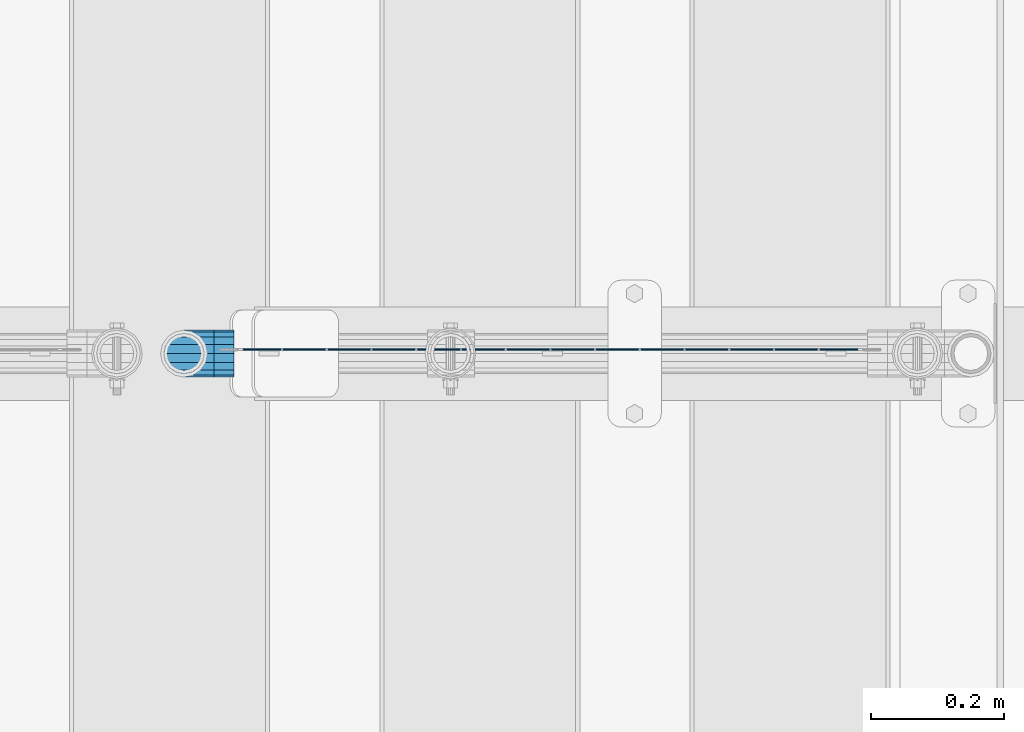
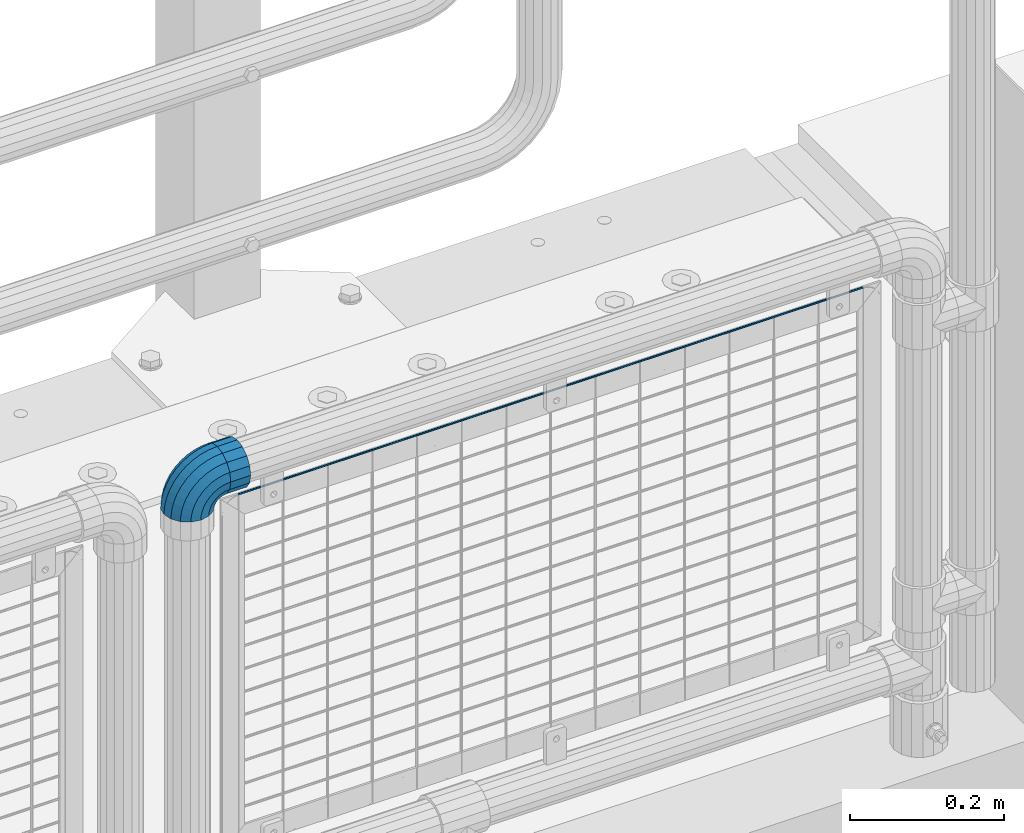
# One storey, part 169 of 247: 2 beams, 1 member.
"""IFC2X3 building model written with IfcOpenShell, lengths in millimetres."""

from ifc_helpers import new_model, si_unit, frame, origin_with_axes, place, context, subcontext, project, spatial, faceted_brep, material, type_object, element, save


model = new_model("IFC2X3")

# Units and contexts
model_context = context("Model", 3, precision=1e-05, world=origin_with_axes())
body_context = subcontext(model_context, "Body", "Model", "MODEL_VIEW")
ifc_project = project(units=[si_unit("LENGTHUNIT", "METRE", prefix="MILLI"), si_unit("AREAUNIT", "SQUARE_METRE"), si_unit("VOLUMEUNIT", "CUBIC_METRE"), si_unit("MASSUNIT", "GRAM", prefix="KILO"), si_unit("TIMEUNIT", "SECOND"), si_unit("PLANEANGLEUNIT", "RADIAN"), si_unit("SOLIDANGLEUNIT", "STERADIAN"), si_unit("THERMODYNAMICTEMPERATUREUNIT", "DEGREE_CELSIUS"), si_unit("LUMINOUSINTENSITYUNIT", "LUMEN")], contexts=[model_context])

# Site, building, storey
site_placement = place(None, origin_with_axes())
site = spatial("IfcSite", under=ifc_project, at=site_placement, CompositionType="ELEMENT")
building_placement = place(site_placement, origin_with_axes())
building = spatial("IfcBuilding", under=site, at=building_placement, Name="Standard", CompositionType="ELEMENT")
storey_placement = place(building_placement, origin_with_axes())
storey = spatial("IfcBuildingStorey", under=building, at=storey_placement, Name="Undefined", CompositionType="ELEMENT", Elevation=0.0)

# Beam
ifc_material = material(Name="Misc_Undefined")
beam_type_1 = type_object("IfcBeamType", PredefinedType="NOTDEFINED")
beam_1_placement = place(storey_placement, frame((15166.61, 7664.5, 969.849999999999), z_axis=(0.0, 0.0, 1.0), x_axis=(1.0, 0.0, 0.0)))
element("IfcBeam", 1, at=beam_1_placement, inside=storey, type_object=beam_type_1, material=ifc_material, context=body_context, shape_type="Brep", body=[
    faceted_brep([(0.0, -30.3500000000004, 0.0), (0.0, -28.0397438117179, 11.6144421722802), (30.0, -28.0397438117179, 11.6144421722805), (30.0, -30.3500000000004, 0.0), (0.0, -21.4606908090118, 21.4606908090118), (30.0, -21.4606908090118, 21.4606908090117), (0.0, -11.6144421722802, 28.0397438117179), (30.0, -11.6144421722802, 28.0397438117175), (0.0, 0.0, 30.3500000000004), (30.0, 0.0, 30.35), (0.0, 11.6144421722802, 28.0397438117179), (30.0, 11.6144421722802, 28.0397438117175), (0.0, 21.4606908090118, 21.4606908090118), (30.0, 21.4606908090118, 21.4606908090117), (0.0, 28.0397438117179, 11.6144421722802), (30.0, 28.0397438117179, 11.6144421722805), (0.0, 30.3500000000004, 0.0), (30.0, 30.3500000000004, 0.0), (0.0, 28.0397438117179, -11.6144421722802), (30.0, 28.0397438117179, -11.6144421722805), (0.0, 21.4606908090118, -21.4606908090118), (30.0, 21.4606908090118, -21.4606908090117), (0.0, 11.6144421722802, -28.0397438117179), (30.0, 11.6144421722802, -28.0397438117175), (0.0, 0.0, -30.3500000000004), (30.0, 0.0, -30.35), (0.0, -11.6144421722802, -28.0397438117179), (30.0, -11.6144421722802, -28.0397438117175), (0.0, -21.4606908090118, -21.4606908090118), (30.0, -21.4606908090118, -21.4606908090117), (0.0, -28.0397438117179, -11.6144421722802), (30.0, -28.0397438117179, -11.6144421722805), (0.0, -35.1499999999996, 0.0), (0.0, -32.4743655677721, -13.4513226476338), (30.0, -32.4743655677721, -13.4513226476329), (30.0, -35.1499999999996, 0.0), (0.0, -24.8548033587067, -24.8548033587067), (30.0, -24.8548033587067, -24.8548033587072), (0.0, -13.4513226476329, -32.4743655677721), (30.0, -13.4513226476329, -32.4743655677717), (0.0, 0.0, -35.1499999999996), (30.0, 0.0, -35.15), (0.0, 13.4513226476329, -32.4743655677721), (30.0, 13.4513226476329, -32.4743655677717), (0.0, 24.8548033587067, -24.8548033587067), (30.0, 24.8548033587067, -24.8548033587072), (0.0, 32.4743655677721, -13.4513226476338), (30.0, 32.4743655677721, -13.4513226476329), (0.0, 35.1499999999996, 0.0), (30.0, 35.1499999999996, 0.0), (0.0, 32.4743655677721, 13.4513226476338), (30.0, 32.4743655677721, 13.4513226476329), (0.0, 24.8548033587067, 24.8548033587067), (30.0, 24.8548033587067, 24.8548033587072), (0.0, 13.4513226476329, 32.4743655677721), (30.0, 13.4513226476329, 32.4743655677717), (0.0, 0.0, 35.1499999999996), (30.0, 0.0, 35.15), (0.0, -13.4513226476329, 32.4743655677721), (30.0, -13.4513226476329, 32.4743655677717), (0.0, -24.8548033587067, 24.8548033587067), (30.0, -24.8548033587067, 24.8548033587072), (0.0, -32.4743655677721, 13.4513226476338), (30.0, -32.4743655677721, 13.4513226476329)], [[[0, 1, 2, 3]], [[1, 4, 5, 2]], [[4, 6, 7, 5]], [[6, 8, 9, 7]], [[8, 10, 11, 9]], [[10, 12, 13, 11]], [[12, 14, 15, 13]], [[14, 16, 17, 15]], [[16, 18, 19, 17]], [[18, 20, 21, 19]], [[20, 22, 23, 21]], [[22, 24, 25, 23]], [[24, 26, 27, 25]], [[26, 28, 29, 27]], [[28, 30, 31, 29]], [[30, 0, 3, 31]], [[32, 33, 34, 35]], [[33, 36, 37, 34]], [[36, 38, 39, 37]], [[38, 40, 41, 39]], [[40, 42, 43, 41]], [[42, 44, 45, 43]], [[44, 46, 47, 45]], [[46, 48, 49, 47]], [[48, 50, 51, 49]], [[50, 52, 53, 51]], [[52, 54, 55, 53]], [[54, 56, 57, 55]], [[56, 58, 59, 57]], [[58, 60, 61, 59]], [[60, 62, 63, 61]], [[62, 32, 35, 63]], [[37, 39, 41, 43, 45, 47, 49, 51, 53, 55, 57, 59, 61, 63, 35, 34], [5, 7, 9, 11, 13, 15, 17, 19, 21, 23, 25, 27, 29, 31, 3, 2]], [[62, 60, 58, 56, 54, 52, 50, 48, 46, 44, 42, 40, 38, 36, 33, 32], [30, 28, 26, 24, 22, 20, 18, 16, 14, 12, 10, 8, 6, 4, 1, 0]]]),
])

# Member
member_type = type_object("IfcMemberType", PredefinedType="NOTDEFINED")
member_placement = place(storey_placement, frame((15121.61, 7664.5, 924.849999999999), z_axis=(-0.707106789186492, 3.85000008583224e-07, 0.707106773186498), x_axis=(0.707106781186548, 0.0, 0.707106781186547)))
element("IfcMember", 2, at=member_placement, inside=storey, type_object=member_type, material=ifc_material, context=body_context, shape_type="Brep", body=[
    faceted_brep([(0.0, -35.1499999999996, 0.0), (9.51152146007007, -32.4743655677721, -9.51152146007007), (13.2759578763416, -32.4743655677721, -6.29638902527768), (5.36946880023424, -35.1499999999996, 4.58595959347804), (17.5750000000007, -24.8548033587067, -17.5750000000007), (19.9787556631127, -24.8548033587067, -15.5219987155633), (22.9628441077039, -13.4513226476329, -22.962844107702), (24.4574219585265, -13.4513226476329, -21.6863540323957), (24.8548033587067, 0.0, -24.8548033587067), (26.0301204183143, 0.0, -23.8509877588021), (22.9628441077039, 13.4513226476329, -22.962844107702), (24.4574219585265, 13.4513226476329, -21.6863540323957), (17.5750000000007, 24.8548033587067, -17.5750000000007), (19.9787556631127, 24.8548033587067, -15.5219987155633), (9.51152146007007, 32.4743655677721, -9.51152146007007), (13.2759578763416, 32.4743655677721, -6.29638902527768), (0.0, 35.1499999999996, 0.0), (5.36946880023424, 35.1499999999996, 4.58595959347804), (-9.51152146007007, 32.4743655677721, 9.51152146007007), (-2.53702027587133, 32.4743655677721, 15.4683082122338), (-17.5749999999989, 24.8548033587067, 17.5749999999989), (-9.23981806264237, 24.8548033587067, 24.6939179025194), (-22.962844107702, 13.4513226476329, 22.962844107702), (-13.718484358058, 13.4513226476329, 30.8582732193499), (-24.8548033587067, 0.0, 24.8548033587067), (-15.2911828178458, 0.0, 33.0229069457564), (-22.962844107702, -13.4513226476329, 22.962844107702), (-13.718484358058, -13.4513226476329, 30.8582732193499), (-17.5749999999989, -24.8548033587067, 17.5749999999989), (-9.23981806264237, -24.8548033587067, 24.6939179025194), (-9.51152146007007, -32.4743655677721, 9.51152146007007), (-2.53702027587133, -32.4743655677721, 15.4683082122338), (0.0, -30.3500000000004, 0.0), (-8.21265081971796, -28.0397438117179, 8.21265081971796), (-1.45732902223608, -28.0397438117179, 13.9822406910371), (5.36946880023424, -30.3500000000004, 4.58595959347804), (-15.1749999999993, -21.4606908090118, 15.1749999999993), (-7.24480876131202, -21.4606908090118, 21.948023168994), (-19.8270929919981, -11.6144421722802, 19.827092992), (-11.1118790903529, -11.6144421722802, 27.2705888550772), (-21.4606908090118, 0.0, 21.4606908090118), (-12.4698136068437, 0.0, 29.139625372758), (-19.8270929919981, 11.6144421722802, 19.827092992), (-11.1118790903529, 11.6144421722802, 27.2705888550772), (-15.1749999999993, 21.4606908090118, 15.1749999999993), (-7.24480876131202, 21.4606908090118, 21.948023168994), (-8.21265081971796, 28.0397438117179, 8.21265081971796), (-1.45732902223608, 28.0397438117179, 13.9822406910371), (0.0, 30.3500000000004, 0.0), (5.36946880023424, 30.3500000000004, 4.58595959347804), (8.21265081971978, 28.0397438117179, -8.21265081971796), (12.1962666227046, 28.0397438117179, -4.81032150408282), (15.1750000000011, 21.4606908090118, -15.1750000000011), (17.9837463617787, 21.4606908090118, -12.776103982038), (19.827092992, 11.6144421722802, -19.827092992), (21.8508166908214, 11.6144421722802, -18.0986696681211), (21.4606908090118, 0.0, -21.4606908090118), (23.2087512073122, 0.0, -19.9677061858038), (19.827092992, -11.6144421722802, -19.827092992), (21.8508166908214, -11.6144421722802, -18.0986696681211), (15.1750000000011, -21.4606908090118, -15.1750000000011), (17.9837463617787, -21.4606908090118, -12.776103982038), (8.21265081971978, -28.0397438117179, -8.21265081971796), (12.1962666227046, -28.0397438117179, -4.81032150408282), (17.4970053560719, -32.4743655677721, -3.70972780292141), (11.3902326651169, -35.1499999999996, 8.27548843508157), (22.6740772628636, -24.8548033587067, -13.8703035149447), (26.1332861179544, -13.4513226476329, -20.6593831546816), (27.347998730962, 0.0, -23.0433908901377), (26.1332861179544, 13.4513226476329, -20.6593831546816), (22.6740772628636, 24.8548033587067, -13.8703035149447), (17.4970053560719, 32.4743655677721, -3.70972780292141), (11.3902326651169, 35.1499999999996, 8.27548843508157), (5.28345997416, 32.4743655677721, 20.2607046730845), (0.106388067368243, 24.8548033587067, 30.4212803851096), (-3.3528207877207, 13.4513226476329, 37.2103600248429), (-4.56753340072828, 0.0, 39.5943677603027), (-3.3528207877207, -13.4513226476329, 37.2103600248429), (0.106388067368243, -24.8548033587067, 30.4212803851096), (5.28345997416, -32.4743655677721, 20.2607046730845), (6.11738625912767, -28.0397438117179, 18.6240321853929), (11.3902326651169, -30.3500000000004, 8.27548843508157), (1.64728291997744, -21.4606908090118, 27.3971039594999), (-1.33954464053386, -11.6144421722802, 33.2590831078905), (-2.38837900197905, 0.0, 35.3175364441977), (-1.33954464053386, 11.6144421722802, 33.2590831078905), (1.64728291997744, 21.4606908090118, 27.3971039594999), (6.11738625912767, 28.0397438117179, 18.6240321853929), (11.3902326651169, 30.3500000000004, 8.27548843508157), (16.663079071106, 28.0397438117179, -2.07305531522979), (21.1331824102544, 21.4606908090118, -10.8461270893367), (24.1200099707676, 11.6144421722802, -16.7081062377292), (25.1688443322109, 0.0, -18.7665595740345), (24.1200099707676, -11.6144421722802, -16.7081062377292), (21.1331824102544, -21.4606908090118, -10.8461270893367), (16.663079071106, -28.0397438117179, -2.07305531522979), (22.0707277014626, -32.4743655677721, -1.81522997693355), (17.9140404065238, -35.1499999999996, 10.9777380798878), (25.5945970362118, -24.8548033587067, -12.6605846156472), (27.9491712485105, -13.4513226476329, -19.9072189058952), (28.7759877588032, 0.0, -22.4518984678889), (27.9491712485105, 13.4513226476329, -19.9072189058952), (25.5945970362118, 24.8548033587067, -12.6605846156472), (22.0707277014626, 32.4743655677721, -1.81522997693355), (17.9140404065238, 35.1499999999996, 10.9777380798878), (13.757353111585, 32.4743655677721, 23.7707061367073), (10.2334837768358, 24.8548033587067, 34.6160607754209), (7.87890956453703, 13.4513226476329, 41.8626950656671), (7.05209305424432, 0.0, 44.4073746276608), (7.87890956453703, -13.4513226476329, 41.8626950656671), (10.2334837768358, -24.8548033587067, 34.6160607754209), (13.757353111585, -32.4743655677721, 23.7707061367073), (14.3249803951039, -28.0397438117179, 22.0237289909692), (17.9140404065238, -30.3500000000004, 10.9777380798878), (11.2823222355109, -21.4606908090118, 31.3880679179929), (9.24928305078174, -11.6144421722802, 37.6451191472679), (8.53537462724307, 0.0, 39.8423033494455), (9.24928305078174, 11.6144421722802, 37.6451191472679), (11.2823222355109, 21.4606908090118, 31.3880679179929), (14.3249803951039, 28.0397438117179, 22.0237289909692), (17.9140404065238, 30.3500000000004, 10.9777380798878), (21.5031004179418, 28.0397438117179, -0.0682528311936039), (24.5457585775348, 21.4606908090118, -9.43259175821731), (26.578797762264, 11.6144421722802, -15.6896429874942), (27.2927061858027, 0.0, -17.8868271896699), (26.578797762264, -11.6144421722802, -15.6896429874942), (24.5457585775348, -21.4606908090118, -9.43259175821731), (21.5031004179418, -28.0397438117179, -0.0682528311936039), (26.884504689051, -32.4743655677721, -0.65954437126311), (24.7802542265854, -35.1499999999996, 12.6261701733856), (28.6684020936846, -24.8548033587067, -11.9226293117936), (29.8603642317012, -13.4513226476329, -19.4483820661262), (30.2789256727501, 0.0, -22.0910749985342), (29.8603642317012, 13.4513226476329, -19.4483820661262), (28.6684020936846, 24.8548033587067, -11.9226293117936), (26.884504689051, 32.4743655677721, -0.65954437126311), (24.7802542265854, 35.1499999999996, 12.6261701733856), (22.6760037641197, 32.4743655677721, 25.9118847180362), (20.8921063594862, 24.8548033587067, 37.1749696585666), (19.7001442214696, 13.4513226476329, 44.7007224128993), (19.2815827804206, 0.0, 47.3434153453054), (19.7001442214696, -13.4513226476329, 44.7007224128993), (20.8921063594862, -24.8548033587067, 37.1749696585666), (22.6760037641197, -32.4743655677721, 25.9118847180362), (22.9633551786228, -28.0397438117179, 24.097619289465), (24.7802542265854, -30.3500000000004, 12.6261701733856), (21.4230625404816, -21.4606908090118, 33.8226442665655), (20.3938719035341, -11.6144421722802, 40.3206982094944), (20.0324682126138, 0.0, 42.6025113104479), (20.3938719035341, 11.6144421722802, 40.3206982094944), (21.4230625404816, 21.4606908090118, 33.8226442665655), (22.9633551786228, 28.0397438117179, 24.097619289465), (24.7802542265854, 30.3500000000004, 12.6261701733856), (26.5971532745461, 28.0397438117179, 1.15472105730987), (28.1374459126855, 21.4606908090118, -8.5703039197906), (29.1666365496367, 11.6144421722802, -15.0683578627213), (29.5280402405569, 0.0, -17.3501709636766), (29.1666365496367, -11.6144421722802, -15.0683578627213), (28.1374459126855, -21.4606908090118, -8.5703039197906), (26.5971532745461, -28.0397438117179, 1.15472105730987), (31.8198051533964, -32.4743655677721, -0.271127801028342), (31.8198051533946, -35.1499999999996, 13.1801948466054), (31.8198051533964, -24.8548033587067, -11.6746085121031), (31.8198051533964, -13.4513226476329, -19.2941707211648), (31.8198051533964, 0.0, -21.969805153396), (31.8198051533964, 13.4513226476329, -19.2941707211648), (31.8198051533964, 24.8548033587067, -11.6746085121031), (31.8198051533964, 32.4743655677721, -0.271127801028342), (31.8198051533946, 35.1499999999996, 13.1801948466054), (31.8198051533946, 32.4743655677721, 26.6315174942392), (31.8198051533946, 24.8548033587067, 38.0349982053121), (31.8198051533964, 13.4513226476329, 45.6545604143757), (31.8198051533964, 0.0, 48.3301948466033), (31.8198051533964, -13.4513226476329, 45.6545604143757), (31.8198051533946, -24.8548033587067, 38.0349982053121), (31.8198051533946, -32.4743655677721, 26.6315174942392), (31.8198051533964, -28.0397438117179, 24.7946370188838), (31.8198051533946, -30.3500000000004, 13.1801948466054), (31.8198051533964, -21.4606908090118, 34.6408856556172), (31.8198051533946, -11.6144421722802, 41.2199386583234), (31.8198051533964, 0.0, 43.530194846604), (31.8198051533946, 11.6144421722802, 41.2199386583234), (31.8198051533964, 21.4606908090118, 34.6408856556172), (31.8198051533964, 28.0397438117179, 24.7946370188838), (31.8198051533946, 30.3500000000004, 13.1801948466054), (31.8198051533964, 28.0397438117179, 1.56575267432345), (31.8198051533964, 21.4606908090118, -8.28049596240635), (31.8198051533946, 11.6144421722802, -14.8595489651125), (31.8198051533964, 0.0, -17.1698051533949), (31.8198051533946, -11.6144421722802, -14.8595489651125), (31.8198051533964, -21.4606908090118, -8.28049596240635), (31.8198051533964, -28.0397438117179, 1.56575267432345), (36.7551056177399, -32.4743655677721, -0.659544371264928), (38.8593560802055, -35.1499999999996, 12.6261701733874), (34.9712082131082, -24.8548033587067, -11.9226293117936), (33.7792460750934, -13.4513226476329, -19.4483820661262), (33.3606846340426, 0.0, -22.0910749985342), (33.7792460750934, 13.4513226476329, -19.4483820661262), (34.9712082131082, 24.8548033587067, -11.9226293117936), (36.7551056177399, 32.4743655677721, -0.659544371264928), (38.8593560802055, 35.1499999999996, 12.6261701733874), (40.963606542673, 32.4743655677721, 25.9118847180362), (42.7475039473047, 24.8548033587067, 37.1749696585666), (43.9394660853195, 13.4513226476329, 44.7007224128993), (44.3580275263703, 0.0, 47.3434153453054), (43.9394660853195, -13.4513226476329, 44.7007224128993), (42.7475039473047, -24.8548033587067, 37.1749696585666), (40.963606542673, -32.4743655677721, 25.9118847180362), (40.6762551281663, -28.0397438117179, 24.097619289465), (38.8593560802055, -30.3500000000004, 12.6261701733874), (42.2165477663093, -21.4606908090118, 33.8226442665637), (43.2457384032587, -11.6144421722802, 40.3206982094925), (43.6071420941771, 0.0, 42.6025113104497), (43.2457384032587, 11.6144421722802, 40.3206982094925), (42.2165477663093, 21.4606908090118, 33.8226442665637), (40.6762551281663, 28.0397438117179, 24.097619289465), (38.8593560802055, 30.3500000000004, 12.6261701733874), (37.0424570322448, 28.0397438117179, 1.15472105730805), (35.5021643941036, 21.4606908090118, -8.5703039197906), (34.4729737571543, 11.6144421722802, -15.0683578627213), (34.1115700662358, 0.0, -17.3501709636766), (34.4729737571543, -11.6144421722802, -15.0683578627213), (35.5021643941036, -21.4606908090118, -8.5703039197906), (37.0424570322448, -28.0397438117179, 1.15472105730805), (41.5688826053301, -32.4743655677721, -1.81522997693355), (45.725569900269, -35.1499999999996, 10.9777380798878), (38.045013270581, -24.8548033587067, -12.6605846156453), (35.6904390582822, -13.4513226476329, -19.9072189058934), (34.8636225479895, 0.0, -22.4518984678889), (35.6904390582822, 13.4513226476329, -19.9072189058934), (38.045013270581, 24.8548033587067, -12.6605846156453), (41.5688826053301, 32.4743655677721, -1.81522997693355), (45.725569900269, 35.1499999999996, 10.9777380798878), (49.8822571952078, 32.4743655677721, 23.7707061367073), (53.406126529957, 24.8548033587067, 34.6160607754209), (55.7607007422539, 13.4513226476329, 41.8626950656671), (56.5875172525484, 0.0, 44.4073746276608), (55.7607007422539, -13.4513226476329, 41.8626950656671), (53.406126529957, -24.8548033587067, 34.6160607754209), (49.8822571952078, -32.4743655677721, 23.7707061367073), (49.3146299116888, -28.0397438117179, 22.0237289909674), (45.725569900269, -30.3500000000004, 10.9777380798878), (52.35728807128, -21.4606908090118, 31.3880679179929), (54.3903272560092, -11.6144421722802, 37.6451191472679), (55.1042356795479, 0.0, 39.8423033494455), (54.3903272560092, 11.6144421722802, 37.6451191472679), (52.35728807128, 21.4606908090118, 31.3880679179929), (49.3146299116888, 28.0397438117179, 22.0237289909674), (45.725569900269, 30.3500000000004, 10.9777380798878), (42.1365098888491, 28.0397438117179, -0.0682528311936039), (39.0938517292579, 21.4606908090118, -9.43259175821913), (37.0608125445287, 11.6144421722802, -15.6896429874942), (36.3469041209901, 0.0, -17.8868271896699), (37.0608125445287, -11.6144421722802, -15.6896429874942), (39.0938517292579, -21.4606908090118, -9.43259175821913), (42.1365098888491, -28.0397438117179, -0.0682528311936039), (46.1426049507172, -32.4743655677721, -3.70972780292141), (52.2493776416759, -35.1499999999996, 8.27548843508157), (40.9655330439273, -24.8548033587067, -13.8703035149447), (37.5063241888383, -13.4513226476329, -20.6593831546816), (36.2916115758308, 0.0, -23.0433908901396), (37.5063241888383, 13.4513226476329, -20.6593831546816), (40.9655330439273, 24.8548033587067, -13.8703035149447), (46.1426049507172, 32.4743655677721, -3.70972780292141), (52.2493776416759, 35.1499999999996, 8.27548843508157), (58.3561503326328, 32.4743655677721, 20.2607046730845), (63.5332222394227, 24.8548033587067, 30.4212803851078), (66.9924310945134, 13.4513226476329, 37.2103600248447), (68.207143707521, 0.0, 39.5943677603027), (66.9924310945134, -13.4513226476329, 37.2103600248447), (63.5332222394227, -24.8548033587067, 30.4212803851078), (58.3561503326328, -32.4743655677721, 20.2607046730845), (57.5222240476651, -28.0397438117179, 18.6240321853929), (52.2493776416759, -30.3500000000004, 8.27548843508157), (61.9923273868153, -21.4606908090118, 27.3971039594999), (64.9791549473266, -11.6144421722802, 33.2590831078905), (66.0279893087718, 0.0, 35.3175364441995), (64.9791549473266, 11.6144421722802, 33.2590831078905), (61.9923273868153, 21.4606908090118, 27.3971039594999), (57.5222240476651, 28.0397438117179, 18.6240321853929), (52.2493776416759, 30.3500000000004, 8.27548843508157), (46.9765312356867, 28.0397438117179, -2.07305531522979), (42.5064278965383, 21.4606908090118, -10.8461270893367), (39.5196003360252, 11.6144421722802, -16.7081062377292), (38.47076597458, 0.0, -18.7665595740345), (39.5196003360252, -11.6144421722802, -16.7081062377292), (42.5064278965383, -21.4606908090118, -10.8461270893367), (46.9765312356867, -28.0397438117179, -2.07305531522979), (50.3636524304511, -32.4743655677721, -6.29638902527768), (58.2701415065567, -35.1499999999996, 4.58595959347804), (43.6608546436782, -24.8548033587067, -15.5219987155633), (39.1821883482662, -13.4513226476329, -21.6863540323939), (37.6094898884767, 0.0, -23.8509877588021), (39.1821883482662, 13.4513226476329, -21.6863540323939), (43.6608546436782, 24.8548033587067, -15.5219987155633), (50.3636524304511, 32.4743655677721, -6.29638902527768), (58.2701415065567, 35.1499999999996, 4.58595959347804), (66.1766305826623, 32.4743655677721, 15.4683082122338), (72.8794283694351, 24.8548033587067, 24.6939179025212), (77.3580946648472, 13.4513226476329, 30.8582732193499), (78.9307931246385, 0.0, 33.0229069457564), (77.3580946648472, -13.4513226476329, 30.8582732193499), (72.8794283694351, -24.8548033587067, 24.6939179025212), (66.1766305826623, -32.4743655677721, 15.4683082122338), (65.096939329027, -28.0397438117179, 13.9822406910371), (58.2701415065567, -30.3500000000004, 4.58595959347804), (70.8844190681029, -21.4606908090118, 21.948023168994), (74.7514893971438, -11.6144421722802, 27.2705888550772), (76.1094239136346, 0.0, 29.139625372758), (74.7514893971438, 11.6144421722802, 27.2705888550772), (70.8844190681029, 21.4606908090118, 21.948023168994), (65.096939329027, 28.0397438117179, 13.9822406910371), (58.2701415065567, 30.3500000000004, 4.58595959347804), (51.4433436840882, 28.0397438117179, -4.810321504081), (45.6558639450104, 21.4606908090118, -12.776103982038), (41.7887936159714, 11.6144421722802, -18.0986696681211), (40.4308590994806, 0.0, -19.9677061858019), (41.7887936159714, -11.6144421722802, -18.0986696681211), (45.6558639450104, -21.4606908090118, -12.776103982038), (51.4433436840882, -28.0397438117179, -4.810321504081), (54.1280888467209, -32.4743655677721, -9.51152146007007), (63.6396103067891, -35.1499999999996, 0.0), (46.0646103067902, -24.8548033587067, -17.5750000000007), (40.6767661990871, -13.4513226476329, -22.962844107702), (38.7848069480824, 0.0, -24.8548033587067), (40.6767661990871, 13.4513226476329, -22.962844107702), (46.0646103067902, 24.8548033587067, -17.5750000000007), (54.1280888467209, 32.4743655677721, -9.51152146007007), (63.6396103067891, 35.1499999999996, 0.0), (73.1511317668592, 32.4743655677721, 9.51152146007007), (81.2146103067898, 24.8548033587067, 17.5750000000007), (86.602454414493, 13.4513226476329, 22.962844107702), (88.4944136654976, 0.0, 24.8548033587067), (86.602454414493, -13.4513226476329, 22.962844107702), (81.2146103067898, -24.8548033587067, 17.5750000000007), (73.1511317668592, -32.4743655677721, 9.51152146007007), (71.8522611265089, -28.0397438117179, 8.21265081971796), (63.6396103067891, -30.3500000000004, 0.0), (78.8146103067902, -21.4606908090118, 15.1749999999993), (83.4667032987891, -11.6144421722802, 19.8270929919981), (85.1003011158009, 0.0, 21.4606908090118), (83.4667032987891, 11.6144421722802, 19.8270929919981), (78.8146103067902, 21.4606908090118, 15.1749999999993), (71.8522611265089, 28.0397438117179, 8.21265081971796), (63.6396103067891, 30.3500000000004, 0.0), (55.4269594870711, 28.0397438117179, -8.21265081971796), (48.4646103067898, 21.4606908090118, -15.1749999999993), (43.812517314791, 11.6144421722802, -19.8270929919981), (42.1789194977791, 0.0, -21.4606908090118), (43.812517314791, -11.6144421722802, -19.8270929919981), (48.4646103067898, -21.4606908090118, -15.1749999999993), (55.4269594870711, -28.0397438117179, -8.21265081971796)], [[[0, 1, 2, 3]], [[1, 4, 5, 2]], [[4, 6, 7, 5]], [[6, 8, 9, 7]], [[8, 10, 11, 9]], [[10, 12, 13, 11]], [[12, 14, 15, 13]], [[14, 16, 17, 15]], [[16, 18, 19, 17]], [[18, 20, 21, 19]], [[20, 22, 23, 21]], [[22, 24, 25, 23]], [[24, 26, 27, 25]], [[26, 28, 29, 27]], [[28, 30, 31, 29]], [[30, 0, 3, 31]], [[32, 33, 34, 35]], [[33, 36, 37, 34]], [[36, 38, 39, 37]], [[38, 40, 41, 39]], [[40, 42, 43, 41]], [[42, 44, 45, 43]], [[44, 46, 47, 45]], [[46, 48, 49, 47]], [[48, 50, 51, 49]], [[50, 52, 53, 51]], [[52, 54, 55, 53]], [[54, 56, 57, 55]], [[56, 58, 59, 57]], [[58, 60, 61, 59]], [[60, 62, 63, 61]], [[62, 32, 35, 63]], [[30, 28, 26, 24, 22, 20, 18, 16, 14, 12, 10, 8, 6, 4, 1, 0], [62, 60, 58, 56, 54, 52, 50, 48, 46, 44, 42, 40, 38, 36, 33, 32]], [[3, 2, 64, 65]], [[2, 5, 66, 64]], [[5, 7, 67, 66]], [[7, 9, 68, 67]], [[9, 11, 69, 68]], [[11, 13, 70, 69]], [[13, 15, 71, 70]], [[15, 17, 72, 71]], [[17, 19, 73, 72]], [[19, 21, 74, 73]], [[21, 23, 75, 74]], [[23, 25, 76, 75]], [[25, 27, 77, 76]], [[27, 29, 78, 77]], [[29, 31, 79, 78]], [[31, 3, 65, 79]], [[35, 34, 80, 81]], [[34, 37, 82, 80]], [[37, 39, 83, 82]], [[39, 41, 84, 83]], [[41, 43, 85, 84]], [[43, 45, 86, 85]], [[45, 47, 87, 86]], [[47, 49, 88, 87]], [[49, 51, 89, 88]], [[51, 53, 90, 89]], [[53, 55, 91, 90]], [[55, 57, 92, 91]], [[57, 59, 93, 92]], [[59, 61, 94, 93]], [[61, 63, 95, 94]], [[63, 35, 81, 95]], [[65, 64, 96, 97]], [[64, 66, 98, 96]], [[66, 67, 99, 98]], [[67, 68, 100, 99]], [[68, 69, 101, 100]], [[69, 70, 102, 101]], [[70, 71, 103, 102]], [[71, 72, 104, 103]], [[72, 73, 105, 104]], [[73, 74, 106, 105]], [[74, 75, 107, 106]], [[75, 76, 108, 107]], [[76, 77, 109, 108]], [[77, 78, 110, 109]], [[78, 79, 111, 110]], [[79, 65, 97, 111]], [[81, 80, 112, 113]], [[80, 82, 114, 112]], [[82, 83, 115, 114]], [[83, 84, 116, 115]], [[84, 85, 117, 116]], [[85, 86, 118, 117]], [[86, 87, 119, 118]], [[87, 88, 120, 119]], [[88, 89, 121, 120]], [[89, 90, 122, 121]], [[90, 91, 123, 122]], [[91, 92, 124, 123]], [[92, 93, 125, 124]], [[93, 94, 126, 125]], [[94, 95, 127, 126]], [[95, 81, 113, 127]], [[97, 96, 128, 129]], [[96, 98, 130, 128]], [[98, 99, 131, 130]], [[99, 100, 132, 131]], [[100, 101, 133, 132]], [[101, 102, 134, 133]], [[102, 103, 135, 134]], [[103, 104, 136, 135]], [[104, 105, 137, 136]], [[105, 106, 138, 137]], [[106, 107, 139, 138]], [[107, 108, 140, 139]], [[108, 109, 141, 140]], [[109, 110, 142, 141]], [[110, 111, 143, 142]], [[111, 97, 129, 143]], [[113, 112, 144, 145]], [[112, 114, 146, 144]], [[114, 115, 147, 146]], [[115, 116, 148, 147]], [[116, 117, 149, 148]], [[117, 118, 150, 149]], [[118, 119, 151, 150]], [[119, 120, 152, 151]], [[120, 121, 153, 152]], [[121, 122, 154, 153]], [[122, 123, 155, 154]], [[123, 124, 156, 155]], [[124, 125, 157, 156]], [[125, 126, 158, 157]], [[126, 127, 159, 158]], [[127, 113, 145, 159]], [[129, 128, 160, 161]], [[128, 130, 162, 160]], [[130, 131, 163, 162]], [[131, 132, 164, 163]], [[132, 133, 165, 164]], [[133, 134, 166, 165]], [[134, 135, 167, 166]], [[135, 136, 168, 167]], [[136, 137, 169, 168]], [[137, 138, 170, 169]], [[138, 139, 171, 170]], [[139, 140, 172, 171]], [[140, 141, 173, 172]], [[141, 142, 174, 173]], [[142, 143, 175, 174]], [[143, 129, 161, 175]], [[145, 144, 176, 177]], [[144, 146, 178, 176]], [[146, 147, 179, 178]], [[147, 148, 180, 179]], [[148, 149, 181, 180]], [[149, 150, 182, 181]], [[150, 151, 183, 182]], [[151, 152, 184, 183]], [[152, 153, 185, 184]], [[153, 154, 186, 185]], [[154, 155, 187, 186]], [[155, 156, 188, 187]], [[156, 157, 189, 188]], [[157, 158, 190, 189]], [[158, 159, 191, 190]], [[159, 145, 177, 191]], [[161, 160, 192, 193]], [[160, 162, 194, 192]], [[162, 163, 195, 194]], [[163, 164, 196, 195]], [[164, 165, 197, 196]], [[165, 166, 198, 197]], [[166, 167, 199, 198]], [[167, 168, 200, 199]], [[168, 169, 201, 200]], [[169, 170, 202, 201]], [[170, 171, 203, 202]], [[171, 172, 204, 203]], [[172, 173, 205, 204]], [[173, 174, 206, 205]], [[174, 175, 207, 206]], [[175, 161, 193, 207]], [[177, 176, 208, 209]], [[176, 178, 210, 208]], [[178, 179, 211, 210]], [[179, 180, 212, 211]], [[180, 181, 213, 212]], [[181, 182, 214, 213]], [[182, 183, 215, 214]], [[183, 184, 216, 215]], [[184, 185, 217, 216]], [[185, 186, 218, 217]], [[186, 187, 219, 218]], [[187, 188, 220, 219]], [[188, 189, 221, 220]], [[189, 190, 222, 221]], [[190, 191, 223, 222]], [[191, 177, 209, 223]], [[193, 192, 224, 225]], [[192, 194, 226, 224]], [[194, 195, 227, 226]], [[195, 196, 228, 227]], [[196, 197, 229, 228]], [[197, 198, 230, 229]], [[198, 199, 231, 230]], [[199, 200, 232, 231]], [[200, 201, 233, 232]], [[201, 202, 234, 233]], [[202, 203, 235, 234]], [[203, 204, 236, 235]], [[204, 205, 237, 236]], [[205, 206, 238, 237]], [[206, 207, 239, 238]], [[207, 193, 225, 239]], [[209, 208, 240, 241]], [[208, 210, 242, 240]], [[210, 211, 243, 242]], [[211, 212, 244, 243]], [[212, 213, 245, 244]], [[213, 214, 246, 245]], [[214, 215, 247, 246]], [[215, 216, 248, 247]], [[216, 217, 249, 248]], [[217, 218, 250, 249]], [[218, 219, 251, 250]], [[219, 220, 252, 251]], [[220, 221, 253, 252]], [[221, 222, 254, 253]], [[222, 223, 255, 254]], [[223, 209, 241, 255]], [[225, 224, 256, 257]], [[224, 226, 258, 256]], [[226, 227, 259, 258]], [[227, 228, 260, 259]], [[228, 229, 261, 260]], [[229, 230, 262, 261]], [[230, 231, 263, 262]], [[231, 232, 264, 263]], [[232, 233, 265, 264]], [[233, 234, 266, 265]], [[234, 235, 267, 266]], [[235, 236, 268, 267]], [[236, 237, 269, 268]], [[237, 238, 270, 269]], [[238, 239, 271, 270]], [[239, 225, 257, 271]], [[241, 240, 272, 273]], [[240, 242, 274, 272]], [[242, 243, 275, 274]], [[243, 244, 276, 275]], [[244, 245, 277, 276]], [[245, 246, 278, 277]], [[246, 247, 279, 278]], [[247, 248, 280, 279]], [[248, 249, 281, 280]], [[249, 250, 282, 281]], [[250, 251, 283, 282]], [[251, 252, 284, 283]], [[252, 253, 285, 284]], [[253, 254, 286, 285]], [[254, 255, 287, 286]], [[255, 241, 273, 287]], [[257, 256, 288, 289]], [[256, 258, 290, 288]], [[258, 259, 291, 290]], [[259, 260, 292, 291]], [[260, 261, 293, 292]], [[261, 262, 294, 293]], [[262, 263, 295, 294]], [[263, 264, 296, 295]], [[264, 265, 297, 296]], [[265, 266, 298, 297]], [[266, 267, 299, 298]], [[267, 268, 300, 299]], [[268, 269, 301, 300]], [[269, 270, 302, 301]], [[270, 271, 303, 302]], [[271, 257, 289, 303]], [[273, 272, 304, 305]], [[272, 274, 306, 304]], [[274, 275, 307, 306]], [[275, 276, 308, 307]], [[276, 277, 309, 308]], [[277, 278, 310, 309]], [[278, 279, 311, 310]], [[279, 280, 312, 311]], [[280, 281, 313, 312]], [[281, 282, 314, 313]], [[282, 283, 315, 314]], [[283, 284, 316, 315]], [[284, 285, 317, 316]], [[285, 286, 318, 317]], [[286, 287, 319, 318]], [[287, 273, 305, 319]], [[289, 288, 320, 321]], [[288, 290, 322, 320]], [[290, 291, 323, 322]], [[291, 292, 324, 323]], [[292, 293, 325, 324]], [[293, 294, 326, 325]], [[294, 295, 327, 326]], [[295, 296, 328, 327]], [[296, 297, 329, 328]], [[297, 298, 330, 329]], [[298, 299, 331, 330]], [[299, 300, 332, 331]], [[300, 301, 333, 332]], [[301, 302, 334, 333]], [[302, 303, 335, 334]], [[303, 289, 321, 335]], [[305, 304, 336, 337]], [[304, 306, 338, 336]], [[306, 307, 339, 338]], [[307, 308, 340, 339]], [[308, 309, 341, 340]], [[309, 310, 342, 341]], [[310, 311, 343, 342]], [[311, 312, 344, 343]], [[312, 313, 345, 344]], [[313, 314, 346, 345]], [[314, 315, 347, 346]], [[315, 316, 348, 347]], [[316, 317, 349, 348]], [[317, 318, 350, 349]], [[318, 319, 351, 350]], [[319, 305, 337, 351]], [[322, 323, 324, 325, 326, 327, 328, 329, 330, 331, 332, 333, 334, 335, 321, 320], [338, 339, 340, 341, 342, 343, 344, 345, 346, 347, 348, 349, 350, 351, 337, 336]]]),
])

# Beam
beam_type_2 = type_object("IfcBeamType", Name="D3", PredefinedType="NOTDEFINED")
beam_2_placement = place(storey_placement, frame((15201.61, 7670.49998304, 913.02), z_axis=(0.0, 0.0, 1.0), x_axis=(1.0, 0.0, 0.0)))
element("IfcBeam", 3, at=beam_2_placement, inside=storey, type_object=beam_type_2, material=ifc_material, ObjectType="D3", context=body_context, shape_type="Brep", body=[
    faceted_brep([(1.81898940354586e-12, -1.5, -5.6843418860808e-14), (0.0, -0.75, -1.29903810567703), (938.390000000096, -0.749999999999091, -1.29903810567669), (938.390000000096, -1.49999999999909, 0.0), (0.0, 0.75, -1.29903810567703), (938.390000000096, 0.750000000000909, -1.29903810567663), (1.81898940354586e-12, 1.5, -5.6843418860808e-14), (938.390000000096, 1.50000000000091, 0.0), (0.0, 0.75, 1.29903810567703), (938.390000000096, 0.750000000000909, 1.29903810567669), (0.0, -0.75, 1.29903810567703), (938.390000000096, -0.749999999999091, 1.29903810567669)], [[[0, 1, 2, 3]], [[1, 4, 5, 2]], [[4, 6, 7, 5]], [[6, 8, 9, 7]], [[8, 10, 11, 9]], [[10, 0, 3, 11]], [[5, 7, 9, 11, 3, 2]], [[10, 8, 6, 4, 1, 0]]]),
])

save(model, "model.ifc")
